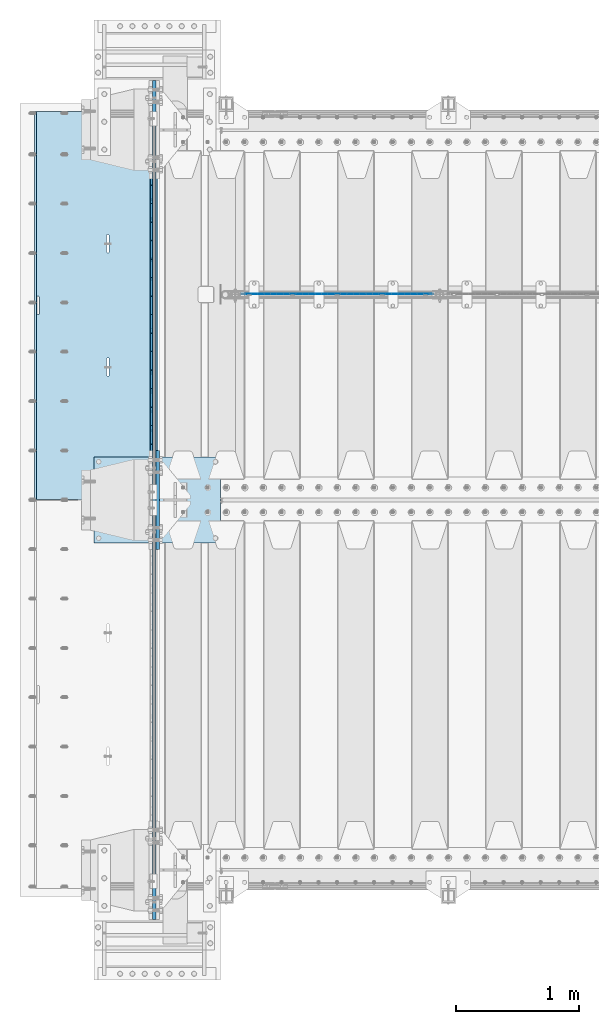
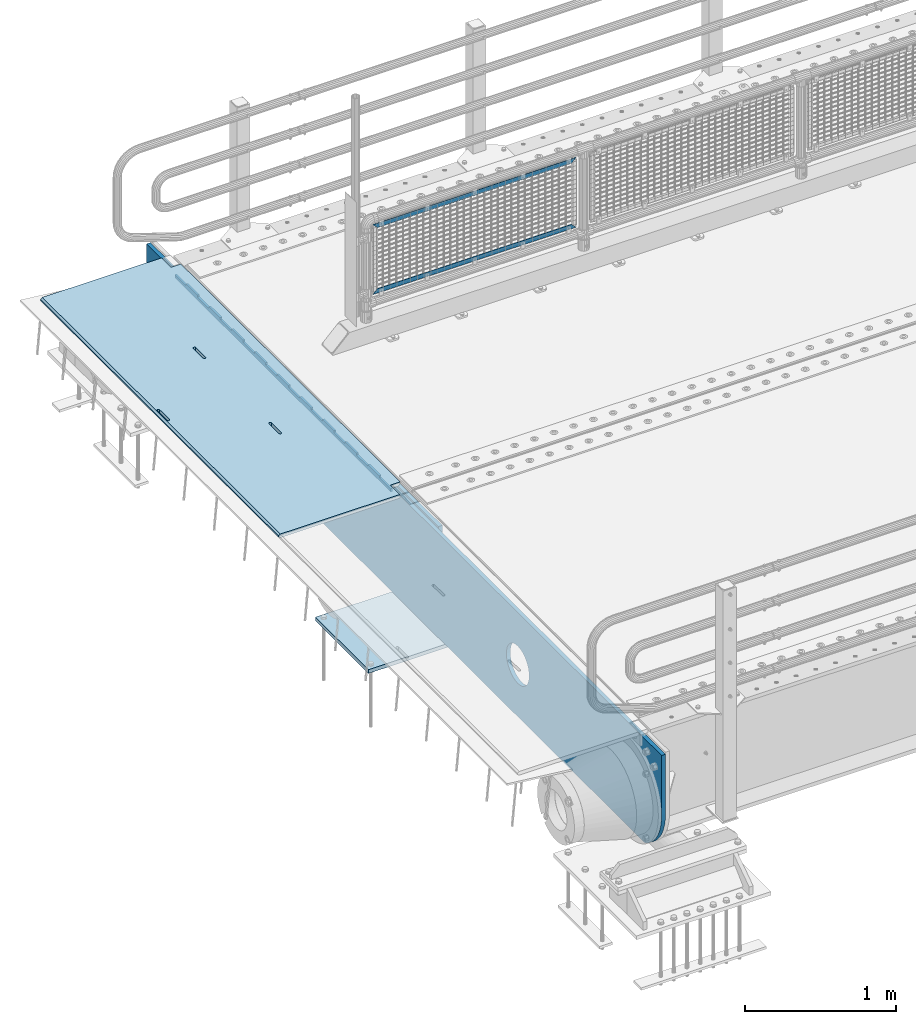
# One storey, part 151 of 193: 7 plates.
"""IFC2X3 building model written with IfcOpenShell, lengths in millimetres."""

from ifc_helpers import new_model, si_unit, frame, origin_with_axes, place, context, subcontext, project, spatial, faceted_brep, material, type_object, element, save


model = new_model("IFC2X3")

# Units and contexts
model_context = context("Model", 3, precision=1e-05, world=origin_with_axes())
body_context = subcontext(model_context, "Body", "Model", "MODEL_VIEW")
ifc_project = project(units=[si_unit("LENGTHUNIT", "METRE", prefix="MILLI"), si_unit("AREAUNIT", "SQUARE_METRE"), si_unit("VOLUMEUNIT", "CUBIC_METRE"), si_unit("MASSUNIT", "GRAM", prefix="KILO"), si_unit("TIMEUNIT", "SECOND"), si_unit("PLANEANGLEUNIT", "RADIAN"), si_unit("SOLIDANGLEUNIT", "STERADIAN"), si_unit("THERMODYNAMICTEMPERATUREUNIT", "DEGREE_CELSIUS"), si_unit("LUMINOUSINTENSITYUNIT", "LUMEN")], contexts=[model_context])

# Site, building, storey
site_placement = place(None, origin_with_axes())
site = spatial("IfcSite", under=ifc_project, at=site_placement, CompositionType="ELEMENT")
building_placement = place(site_placement, origin_with_axes())
building = spatial("IfcBuilding", under=site, at=building_placement, Name="Standard", CompositionType="ELEMENT")
storey_placement = place(building_placement, origin_with_axes())
storey = spatial("IfcBuildingStorey", under=building, at=storey_placement, Name="Undefined", CompositionType="ELEMENT", Elevation=0.0)

# Plates
ifc_material_1 = material(Name="STEEL/S355N")
plate_type_1 = type_object("IfcPlateType", PredefinedType="NOTDEFINED")
plate_1_placement = place(storey_placement, frame((-42455.0037545708, 30149.9999261294, -0.984391683580506), z_axis=(1.0000003385235e-09, -0.999999999987744, -4.95099999993936e-06), x_axis=(-0.999999999879068, -1.00000022173606e-09, -1.55519999981193e-05)))
element("IfcPlate", 1, at=plate_1_placement, inside=storey, type_object=plate_type_1, material=ifc_material_1, context=body_context, shape_type="Brep", body=[
    faceted_brep([(14.9998601691696, 15.0, 125.00002482082), (-0.000294611323624849, -0.000806902962788181, 124.99993624862), (-0.00191941575758392, 0.000806844426834874, 3020.00000492302), (14.9966216875182, 15.0, 3020.0000797665), (999.996459960938, 5.0, 0.0), (984.996459960945, 15.0, 3.63797880709171e-12), (984.996459718794, 15.0, 3145.0), (999.996459718786, 5.0, 3145.0), (984.99645996136, -15.0, 3.63797880709171e-12), (999.996459960938, -4.99999999999848, 0.0), (999.996459718786, -4.99999999999849, 3145.0), (984.996459719208, -15.0, 3145.0), (394.996621833991, -14.9999999992854, 1137.4999999981), (394.996621833998, 15.0, 1137.4999999981), (395.486056670808, 15.0, 1140.59016994185), (395.486056670801, -14.9999999992867, 1140.59016994185), (396.906451889779, 15.0, 1143.37785252103), (396.906451889779, -14.9999999992902, 1143.37785252103), (399.118769310437, 15.0, 1145.59016994185), (399.118769310437, -14.9999999992955, 1145.59016994185), (401.906451889503, 15.0, 1147.01056516106), (401.90645188951, -14.999999999302, 1147.01056516106), (404.996621833212, 15.0, 1147.4999999981), (404.996621833212, -14.9999999993092, 1147.4999999981), (408.086791776994, 15.0, 1147.01056516105), (408.086791776994, -14.9999999993163, 1147.01056516106), (410.874474356286, 15.0, 1145.59016994185), (410.874474356286, -14.9999999993227, 1145.59016994185), (413.086791777278, 15.0, 1143.37785252103), (413.086791777278, -14.9999999993277, 1143.37785252103), (414.5071869967, 15.0, 1140.59016994184), (414.507186996707, -14.9999999993308, 1140.59016994184), (414.996621833976, 15.0, 1137.49999999809), (414.996621833976, -14.9999999993318, 1137.49999999809), (414.996621843893, 15.0, 1007.49999999809), (414.996621843893, -14.9999999993243, 1007.49999999809), (414.507187007082, 15.0, 1004.40983005434), (414.50718700709, -14.999999999323, 1004.40983005435), (413.086791788097, 15.0, 1001.62214747518), (413.086791788097, -14.9999999993196, 1001.62214747518), (410.87447436744, 15.0, 999.409830054352), (410.87447436744, -14.9999999993143, 999.409830054352), (408.086791788373, 15.0, 997.989434835148), (408.086791788373, -14.9999999993078, 997.989434835152), (404.996621844781, 15.0, 997.499999998101), (404.996621844781, -14.9999999993006, 997.499999998101), (401.906451900992, 15.0, 997.989434835152), (401.906451900999, -14.9999999992934, 997.989434835152), (399.1187693217, 15.0, 999.409830054352), (399.118769321707, -14.999999999287, 999.409830054352), (396.906451900715, 15.0, 1001.62214747518), (396.906451900715, -14.999999999282, 1001.62214747518), (395.486056681293, 15.0, 1004.40983005435), (395.486056681293, -14.9999999992789, 1004.40983005435), (394.99662184401, 15.0, 1007.4999999981), (394.99662184401, -14.999999999278, 1007.4999999981), (960.486056642796, -15.0000000006174, 1504.4098300541), (960.486056642796, 15.0, 1504.4098300541), (959.996621805512, 15.0, 1507.49999999785), (959.996621805512, -15.0000000006165, 1507.49999999785), (961.906451862218, -15.0000000006206, 1501.62214747493), (961.906451862218, 15.0, 1501.62214747493), (964.118769283217, -15.0000000006256, 1499.4098300541), (964.11876928321, 15.0, 1499.4098300541), (966.906451862502, -15.0000000006319, 1497.9894348349), (966.906451862495, 15.0, 1497.9894348349), (969.996621806284, -15.0000000006391, 1497.49999999785), (969.996621806284, 15.0, 1497.49999999785), (973.086791749884, -15.0000000006463, 1497.9894348349), (973.086791749884, 15.0, 1497.9894348349), (975.874474328943, -15.0000000006528, 1499.4098300541), (975.874474328943, 15.0, 1499.4098300541), (978.0867917496, -15.0000000006581, 1501.62214747492), (978.0867917496, 15.0, 1501.62214747492), (979.507186968585, -15.0000000006615, 1504.4098300541), (979.507186968578, 15.0, 1504.4098300541), (979.996621805396, -15.0000000006628, 1507.49999999784), (979.996621805396, 15.0, 1507.49999999784), (979.996621795486, -15.0000000006703, 1637.49999999784), (979.996621795486, 15.0, 1637.49999999784), (979.50718695821, -15.0000000006694, 1640.5901699416), (979.507186958203, 15.0, 1640.5901699416), (978.08679173878, -15.0000000006662, 1643.37785252077), (978.08679173878, 15.0, 1643.37785252077), (975.874474317789, -15.0000000006612, 1645.5901699416), (975.874474317789, 15.0, 1645.5901699416), (973.086791738504, -15.0000000006549, 1647.01056516081), (973.086791738504, 15.0, 1647.01056516081), (969.996621794708, -15.0000000006477, 1647.49999999785), (969.996621794715, 15.0, 1647.49999999785), (966.906451851013, -15.0000000006405, 1647.0105651608), (966.906451851006, 15.0, 1647.0105651608), (964.118769271947, -15.000000000634, 1645.5901699416), (964.118769271947, 15.0, 1645.5901699416), (961.906451851282, -15.0000000006287, 1643.37785252078), (961.906451851282, 15.0, 1643.37785252078), (960.486056632304, -15.0000000006253, 1640.5901699416), (960.486056632304, 15.0, 1640.5901699416), (959.996621795493, -15.000000000624, 1637.49999999785), (959.996621795493, 15.0, 1637.49999999785), (-0.000449375176685862, -14.9999999951863, 124.999861417731), (-0.000460362061858177, -15.00000004538, 3019.99993008589), (74.9964039659026, -14.999999998652, 3019.9999301541), (74.9968705259016, 15.0, 3020.0000798241), (74.9962640910162, -15.0, 3145.0), (74.9967306510152, 15.0, 3145.0), (74.9997820616045, -15.0, 3.63797880709171e-12), (75.0002485915975, 15.0, 0.0), (74.9996421867036, -15.0, 124.99993008409), (75.0001087167111, 15.0, 125.000079754089), (395.4860565938, -15.0000000032097, 2140.59016994137), (396.906451812785, -15.0000000031847, 2143.37785252055), (399.118769233435, -15.0000000031445, 2145.59016994137), (401.906451812501, -15.0000000030931, 2147.01056516058), (404.996621756211, -15.0000000030354, 2147.49999999762), (408.086791699992, -15.0000000029771, 2147.01056516058), (410.874474279277, -15.000000002924, 2145.59016994137), (413.086791700283, -15.0000000028812, 2143.37785252055), (414.507186919698, -15.000000002853, 2140.59016994136), (414.996621756974, -15.000000002842, 2137.49999999761), (414.996621766892, -15.0000000027658, 2007.49999999761), (414.507186930088, -15.0000000027732, 2004.40983005387), (413.086791711088, -15.0000000027982, 2001.6221474747), (410.874474290431, -15.0000000028384, 1999.40983005387), (408.086791711372, -15.0000000028898, 1997.98943483467), (404.996621767779, -15.0000000029475, 1997.49999999762), (401.90645182399, -15.0000000030057, 1997.98943483468), (399.118769244706, -15.0000000030589, 1999.40983005387), (396.906451823714, -15.0000000031016, 2001.6221474747), (395.486056604299, -15.0000000031299, 2004.40983005387), (394.996621767008, -15.0000000031409, 2007.49999999762), (394.996621756989, -15.0000000032171, 2137.49999999762), (396.906451823714, 15.0, 2001.6221474747), (395.486056604299, 15.0, 2004.40983005387), (399.118769244698, 15.0, 1999.40983005387), (401.906451823983, 15.0, 1997.98943483467), (404.996621767779, 15.0, 1997.49999999762), (408.086791711372, 15.0, 1997.98943483467), (410.874474290438, 15.0, 1999.40983005387), (413.086791711095, 15.0, 2001.62214747469), (414.507186930081, 15.0, 2004.40983005386), (414.996621766892, 15.0, 2007.49999999761), (414.996621756974, 15.0, 2137.49999999761), (414.507186919691, 15.0, 2140.59016994136), (413.086791700283, 15.0, 2143.37785252055), (410.874474279284, 15.0, 2145.59016994137), (408.086791699992, 15.0, 2147.01056516057), (404.996621756211, 15.0, 2147.49999999762), (401.906451812494, 15.0, 2147.01056516057), (399.118769233435, 15.0, 2145.59016994137), (396.906451812785, 15.0, 2143.37785252055), (395.4860565938, 15.0, 2140.59016994137), (394.996621756989, 15.0, 2137.49999999762), (394.996621767008, 15.0, 2007.49999999762)], [[[0, 1, 2, 3]], [[4, 5, 6, 7]], [[8, 9, 10, 11]], [[12, 13, 14, 15]], [[15, 14, 16, 17]], [[17, 16, 18, 19]], [[19, 18, 20, 21]], [[21, 20, 22, 23]], [[23, 22, 24, 25]], [[25, 24, 26, 27]], [[27, 26, 28, 29]], [[29, 28, 30, 31]], [[31, 30, 32, 33]], [[33, 32, 34, 35]], [[35, 34, 36, 37]], [[37, 36, 38, 39]], [[39, 38, 40, 41]], [[41, 40, 42, 43]], [[43, 42, 44, 45]], [[45, 44, 46, 47]], [[47, 46, 48, 49]], [[49, 48, 50, 51]], [[51, 50, 52, 53]], [[53, 52, 54, 55]], [[55, 54, 13, 12]], [[56, 57, 58, 59]], [[60, 61, 57, 56]], [[62, 63, 61, 60]], [[64, 65, 63, 62]], [[66, 67, 65, 64]], [[68, 69, 67, 66]], [[70, 71, 69, 68]], [[72, 73, 71, 70]], [[74, 75, 73, 72]], [[76, 77, 75, 74]], [[78, 79, 77, 76]], [[80, 81, 79, 78]], [[82, 83, 81, 80]], [[84, 85, 83, 82]], [[86, 87, 85, 84]], [[88, 89, 87, 86]], [[90, 91, 89, 88]], [[92, 93, 91, 90]], [[94, 95, 93, 92]], [[96, 97, 95, 94]], [[98, 99, 97, 96]], [[59, 58, 99, 98]], [[100, 101, 2, 1]], [[101, 102, 103, 3, 2]], [[104, 105, 103, 102]], [[7, 6, 105, 104, 11, 10]], [[4, 7, 10, 9]], [[106, 107, 5, 4, 9, 8]], [[106, 108, 109, 107]], [[109, 108, 100, 1, 0]], [[104, 102, 101, 100, 108, 106, 8, 11], [15, 17, 19, 21, 23, 25, 27, 29, 31, 33, 35, 37, 39, 41, 43, 45, 47, 49, 51, 53, 55, 12], [96, 94, 92, 90, 88, 86, 84, 82, 80, 78, 76, 74, 72, 70, 68, 66, 64, 62, 60, 56, 59, 98], [110, 111, 112, 113, 114, 115, 116, 117, 118, 119, 120, 121, 122, 123, 124, 125, 126, 127, 128, 129, 130, 131]], [[128, 132, 133, 129]], [[127, 134, 132, 128]], [[126, 135, 134, 127]], [[125, 136, 135, 126]], [[124, 137, 136, 125]], [[123, 138, 137, 124]], [[122, 139, 138, 123]], [[121, 140, 139, 122]], [[120, 141, 140, 121]], [[119, 142, 141, 120]], [[118, 143, 142, 119]], [[117, 144, 143, 118]], [[116, 145, 144, 117]], [[115, 146, 145, 116]], [[114, 147, 146, 115]], [[113, 148, 147, 114]], [[112, 149, 148, 113]], [[111, 150, 149, 112]], [[110, 151, 150, 111]], [[131, 152, 151, 110]], [[130, 153, 152, 131]], [[129, 133, 153, 130]], [[107, 109, 0, 3, 103, 105, 6, 5], [50, 48, 46, 44, 42, 40, 38, 36, 34, 32, 30, 28, 26, 24, 22, 20, 18, 16, 14, 13, 54, 52], [132, 134, 135, 136, 137, 138, 139, 140, 141, 142, 143, 144, 145, 146, 147, 148, 149, 150, 151, 152, 153, 133], [61, 63, 65, 67, 69, 71, 73, 75, 77, 79, 81, 83, 85, 87, 89, 91, 93, 95, 97, 99, 58, 57]]]),
])
plate_type_2 = type_object("IfcPlateType", PredefinedType="NOTDEFINED")
plate_2_placement = place(storey_placement, frame((-42507.5, 30002.5000993725, -35.9858217417067), z_axis=(1.0000003385235e-09, -0.999999999987744, -4.95099999993936e-06), x_axis=(0.0, 4.95100000930962e-06, -0.999999999987744)))
element("IfcPlate", 2, at=plate_2_placement, inside=storey, type_object=plate_type_2, material=ifc_material_1, context=body_context, shape_type="Brep", body=[
    faceted_brep([(0.0, -7.5, -3.63797880709171e-12), (8.68993765834603e-12, -7.5, 150.0), (8.68993765834603e-12, 7.5, 150.0), (0.0, 7.5, -3.63797880709171e-12), (-14.9999999999986, -7.5, 149.999999999996), (-14.9999999999986, 7.5, 149.999999999996), (-14.9999999999972, -7.5, 300.0), (-14.9999999999972, 7.5, 300.0), (1.55395696310734e-11, -7.5, 300.0), (1.55395696310734e-11, 7.5, 300.0), (1.87725390787818e-11, -7.5, 449.999999999996), (1.87725390787818e-11, 7.5, 449.999999999996), (-14.9999999999958, -7.5, 449.999999999996), (-14.9999999999958, 7.5, 449.999999999996), (-14.9999999999944, -7.5, 599.999999999996), (-14.9999999999944, 7.5, 599.999999999996), (2.74553713097703e-11, -7.5, 600.0), (2.74553713097703e-11, 7.5, 600.0), (3.24931193063094e-11, -7.5, 750.0), (3.24931193063094e-11, 7.5, 750.0), (-14.999999999993, -7.5, 750.0), (-14.999999999993, 7.5, 750.0), (-14.9999999999916, -7.5, 900.0), (-14.9999999999916, 7.5, 900.0), (4.11830569646554e-11, -7.5, 899.999999999996), (4.11830569646554e-11, 7.5, 899.999999999996), (4.62208049611945e-11, -7.5, 1050.0), (4.62208049611945e-11, 7.5, 1050.0), (-14.9999999999902, -7.5, 1050.0), (-14.9999999999902, 7.5, 1050.0), (-14.9999999999888, -7.5, 1200.0), (-14.9999999999888, 7.5, 1200.0), (5.30917532159947e-11, -7.5, 1200.0), (5.30917532159947e-11, 7.5, 1200.0), (5.99484906160797e-11, -7.5, 1350.0), (5.99484906160797e-11, 7.5, 1350.0), (-14.9999999999873, -7.5, 1350.0), (-14.9999999999873, 7.5, 1350.0), (-14.9999999999859, -7.5, 1500.0), (-14.9999999999859, 7.5, 1500.0), (6.49933440399764e-11, -7.5, 1500.0), (6.49933440399764e-11, 7.5, 1500.0), (7.36761762709648e-11, -7.5, 1650.0), (7.36761762709648e-11, 7.5, 1650.0), (-14.9999999999845, -7.5, 1650.0), (-14.9999999999845, 7.5, 1650.0), (-14.9999999999831, -7.5, 1800.0), (-14.9999999999831, 7.5, 1800.0), (7.6894934863958e-11, -7.5, 1800.0), (7.6894934863958e-11, 7.5, 1800.0), (8.37587776914006e-11, -7.5, 1950.0), (8.37587776914006e-11, 7.5, 1950.0), (-14.9999999999817, -7.5, 1950.0), (-14.9999999999817, 7.5, 1950.0), (-14.9999999999803, -7.5, 2100.0), (-14.9999999999803, 7.5, 2100.0), (9.06297259462008e-11, -7.5, 2100.0), (9.06297259462008e-11, 7.5, 2100.0), (9.56674739427399e-11, -7.5, 2250.0), (9.56674739427399e-11, 7.5, 2250.0), (-14.9999999999789, -7.5, 2250.0), (-14.9999999999789, 7.5, 2250.0), (-14.9999999999775, -7.5, 2400.0), (-14.9999999999775, 7.5, 2400.0), (1.04350306173728e-10, -7.5, 2400.0), (1.04350306173728e-10, 7.5, 2400.0), (1.09388054170267e-10, -7.5, 2550.0), (1.09388054170267e-10, 7.5, 2550.0), (-14.9999999999761, -7.5, 2550.0), (-14.9999999999761, 7.5, 2550.0), (-14.9999999999747, -7.5, 2700.0), (-14.9999999999747, 7.5, 2700.0), (1.14440013021522e-10, -7.5, 2700.0), (1.14440013021522e-10, 7.5, 2700.0), (1.23115739825153e-10, -7.5, 2850.0), (1.23115739825153e-10, 7.5, 2850.0), (25.0000000000267, -7.5, 2850.0), (25.0000000000267, 7.5, 2850.0), (25.0, -7.5, -3.63797880709171e-12), (25.0, 7.5, -3.63797880709171e-12)], [[[0, 1, 2, 3]], [[1, 4, 5, 2]], [[4, 6, 7, 5]], [[6, 8, 9, 7]], [[8, 10, 11, 9]], [[10, 12, 13, 11]], [[12, 14, 15, 13]], [[14, 16, 17, 15]], [[16, 18, 19, 17]], [[18, 20, 21, 19]], [[20, 22, 23, 21]], [[22, 24, 25, 23]], [[24, 26, 27, 25]], [[26, 28, 29, 27]], [[28, 30, 31, 29]], [[30, 32, 33, 31]], [[32, 34, 35, 33]], [[34, 36, 37, 35]], [[36, 38, 39, 37]], [[38, 40, 41, 39]], [[40, 42, 43, 41]], [[42, 44, 45, 43]], [[44, 46, 47, 45]], [[46, 48, 49, 47]], [[48, 50, 51, 49]], [[50, 52, 53, 51]], [[52, 54, 55, 53]], [[54, 56, 57, 55]], [[56, 58, 59, 57]], [[58, 60, 61, 59]], [[60, 62, 63, 61]], [[62, 64, 65, 63]], [[64, 66, 67, 65]], [[66, 68, 69, 67]], [[68, 70, 71, 69]], [[70, 72, 73, 71]], [[72, 74, 75, 73]], [[74, 76, 77, 75]], [[76, 78, 79, 77]], [[78, 0, 3, 79]], [[5, 7, 9, 11, 13, 15, 17, 19, 21, 23, 25, 27, 29, 31, 33, 35, 37, 39, 41, 43, 45, 47, 49, 51, 53, 55, 57, 59, 61, 63, 65, 67, 69, 71, 73, 75, 77, 79, 3, 2]], [[78, 76, 74, 72, 70, 68, 66, 64, 62, 60, 58, 56, 54, 52, 50, 48, 46, 44, 42, 40, 38, 36, 34, 32, 30, 28, 26, 24, 22, 20, 18, 16, 14, 12, 10, 8, 6, 4, 1, 0]]]),
])
ifc_material_2 = material(Name="Misc_Undefined")
plate_type_3 = type_object("IfcPlateType", PredefinedType="NOTDEFINED")
plate_3_placement = place(storey_placement, frame((-41775.4949882696, 28670.5, 351.520303374641), z_axis=(0.0, 0.0, 1.0), x_axis=(1.0, 0.0, 0.0)))
element("IfcPlate", 3, at=plate_3_placement, inside=storey, type_object=plate_type_3, material=ifc_material_2, context=body_context, shape_type="Brep", body=[
    faceted_brep([(0.0, -1.49999999999636, 3.63797880709171e-12), (35.0002975463831, -1.5, 34.9996948242187), (35.0002975463831, 1.5, 34.9996948242187), (0.0, 1.50000000000364, 7.27595761418343e-12), (1515.99035644531, -1.5, 34.9999923706054), (1515.99035644531, 1.5, 34.9999923706054), (1550.98999023437, -1.5, 4.43037606601138e-09), (1550.98999023437, 1.5, 4.43037606601138e-09)], [[[0, 1, 2, 3]], [[1, 4, 5, 2]], [[4, 6, 7, 5]], [[6, 0, 3, 7]], [[5, 7, 3, 2]], [[6, 4, 1, 0]]]),
])
plate_4_placement = place(storey_placement, frame((-40224.4999998124, 28670.5, 914.520000175701), z_axis=(-0.707103624179499, 0.0, 0.707109938179501), x_axis=(-0.707109938179501, 0.0, -0.707103624179499)))
element("IfcPlate", 4, at=plate_4_placement, inside=storey, type_object=plate_type_3, material=ifc_material_2, context=body_context, shape_type="Brep", body=[
    faceted_brep([(0.0, -1.49999999999636, 3.63797880709171e-12), (1096.7275390625, -1.5, 1096.7177734375), (1096.7275390625, 1.5, 1096.7177734375), (0.0, 1.50000000000364, 7.27595761418343e-12), (1096.72045898438, -1.5, 1047.21337890625), (1096.72045898438, 1.5, 1047.21337890625), (49.4976959228552, -1.5, -1.01863406598568e-10), (49.4976959228552, 1.5, -1.01863406598568e-10)], [[[0, 1, 2, 3]], [[1, 4, 5, 2]], [[4, 6, 7, 5]], [[6, 0, 3, 7]], [[5, 7, 3, 2]], [[6, 4, 1, 0]]]),
])
plate_type_4 = type_object("IfcPlateType", PredefinedType="NOTDEFINED")
plate_5_placement = place(storey_placement, frame((-42974.0, 27350.0, -1043.0), z_axis=(1.0, 0.0, 0.0), x_axis=(0.0, -1.0, 0.0)))
element("IfcPlate", 5, at=plate_5_placement, inside=storey, type_object=plate_type_4, material=ifc_material_1, context=body_context, shape_type="Brep", body=[
    faceted_brep([(0.0, -15.0, 0.0), (2.93249104288407e-06, -15.0, 1025.0), (2.93249104288407e-06, 15.0, 1025.0), (0.0, 15.0, 0.0), (700.0, -15.0, 1025.0), (700.0, 15.0, 1025.0), (700.0, -15.0, -7.27595761418343e-12), (700.0, 15.0, -7.27595761418343e-12)], [[[0, 1, 2, 3]], [[1, 4, 5, 2]], [[4, 6, 7, 5]], [[6, 0, 3, 7]], [[5, 7, 3, 2]], [[6, 4, 1, 0]]]),
])
plate_type_5 = type_object("IfcPlateType", PredefinedType="NOTDEFINED")
plate_6_placement = place(storey_placement, frame((-42455.0, 26600.0, -20.0), z_axis=(0.0, 1.0, 0.0), x_axis=(0.0, 0.0, -1.0)))
element("IfcPlate", 6, at=plate_6_placement, inside=storey, type_object=plate_type_5, material=ifc_material_1, context=body_context, shape_type="Brep", body=[
    faceted_brep([(855.0, -15.0, 572.963114671471), (855.0, 15.0, 572.963114671471), (849.182410261268, 15.0, 585.889268817518), (849.182410261268, -15.0, 585.889268817518), (824.19354635745, 15.0, 627.225898692468), (824.19354635745, -15.0, 627.225898692468), (794.404299268433, 15.0, 665.249063296324), (794.404299268433, -15.0, 665.249063296324), (760.249063296315, 15.0, 699.404299268441), (760.249063296315, -15.0, 699.404299268441), (722.225898692465, 15.0, 729.193546357463), (722.225898692465, -15.0, 729.193546357463), (680.889268817516, 15.0, 754.182410261281), (680.889268817516, -15.0, 754.182410261281), (636.841954817028, 15.0, 774.006497074162), (636.841954817028, -15.0, 774.006497074162), (590.726265715042, 15.0, 788.376726970419), (590.726265715042, -15.0, 788.376726970419), (543.214672102154, 15.0, 797.083549639221), (543.214672102154, -15.0, 797.083549639221), (495.0, -15.0, 800.000000000029), (495.0, 15.0, 800.0), (494.999999999412, -15.0, 0.0), (494.999999999412, 15.0, 0.0), (543.214672102129, 15.0, 2.91645036080809), (543.214672102129, -15.0, 2.91645036080809), (590.726265715023, 15.0, 11.6232730296069), (590.726265715023, -15.0, 11.6232730296069), (636.841954817014, 15.0, 25.9935029258631), (636.841954817014, -15.0, 25.9935029258631), (680.889268817507, 15.0, 45.8175897387446), (680.889268817507, -15.0, 45.8175897387446), (722.225898692462, 15.0, 70.8064536425663), (722.225898692462, -15.0, 70.8064536425663), (760.249063296318, 15.0, 100.595700731588), (760.249063296318, -15.0, 100.595700731588), (794.404299268441, 15.0, 134.750936703713), (794.404299268441, -15.0, 134.750936703713), (824.193546357463, 15.0, 172.774101307568), (824.193546357463, -15.0, 172.774101307568), (849.182410261284, 15.0, 214.110731182522), (849.182410261284, -15.0, 214.110731182522), (855.0, -15.0, 227.036885328536), (855.0, 15.0, 227.036885328536), (0.0, -15.0, 0.0), (0.0, 15.0, 0.0), (0.0, 15.0, 800.0), (0.0, -15.0, 800.0)], [[[0, 1, 2, 3]], [[3, 2, 4, 5]], [[5, 4, 6, 7]], [[7, 6, 8, 9]], [[9, 8, 10, 11]], [[11, 10, 12, 13]], [[13, 12, 14, 15]], [[15, 14, 16, 17]], [[17, 16, 18, 19]], [[20, 19, 18, 21]], [[22, 23, 24, 25]], [[25, 24, 26, 27]], [[27, 26, 28, 29]], [[29, 28, 30, 31]], [[31, 30, 32, 33]], [[33, 32, 34, 35]], [[35, 34, 36, 37]], [[37, 36, 38, 39]], [[39, 38, 40, 41]], [[42, 41, 40, 43]], [[42, 43, 1, 0]], [[44, 45, 23, 22]], [[16, 14, 12, 10, 8, 6, 4, 2, 1, 43, 40, 38, 36, 34, 32, 30, 28, 26, 24, 23, 45, 46, 21, 18]], [[44, 47, 46, 45]], [[46, 47, 20, 21]], [[47, 44, 22, 25, 27, 29, 31, 33, 35, 37, 39, 41, 42, 0, 3, 5, 7, 9, 11, 13, 15, 17, 19, 20]]]),
])
plate_type_6 = type_object("IfcPlateType", PredefinedType="NOTDEFINED")
plate_7_placement = place(storey_placement, frame((-42485.0, 23600.0, -35.9999830912049), z_axis=(0.0, 1.0, 0.0), x_axis=(0.0, 0.0, -1.0)))
element("IfcPlate", 7, at=plate_7_placement, inside=storey, type_object=plate_type_6, material=ifc_material_1, context=body_context, shape_type="Brep", body=[
    faceted_brep([(449.263580031862, -15.0, 2047.11778936592), (449.263580031862, 15.0, 2047.11778936592), (477.402546532991, 15.0, 2038.58192701329), (477.402546532991, -15.0, 2038.58192701329), (503.335566547999, 15.0, 2024.72043882638), (503.335566547999, -15.0, 2024.72043882638), (526.066048661114, 15.0, 2006.0660140226), (526.066048661114, -15.0, 2006.0660140226), (544.720473192131, 15.0, 1983.33553168563), (544.720473192131, -15.0, 1983.33553168563), (558.581961067844, 15.0, 1957.40251150429), (558.581961067844, -15.0, 1957.40251150429), (567.117823082802, 15.0, 1929.26354490073), (567.117823082802, -15.0, 1929.26354490073), (570.000030846736, 15.0, 1899.99999658101), (570.000030846736, -15.0, 1899.99999658101), (567.117822731639, 15.0, 1870.73644829589), (567.117822731639, -15.0, 1870.73644829589), (558.581960379014, 15.0, 1842.59748179476), (558.581960379014, -15.0, 1842.59748179476), (544.720472192104, 15.0, 1816.66446177975), (544.720472192104, -15.0, 1816.66446177975), (526.066047388322, 15.0, 1793.93397966664), (526.066047388322, -15.0, 1793.93397966664), (503.335565051353, 15.0, 1775.27955513562), (503.335565051353, -15.0, 1775.27955513562), (477.402544870008, 15.0, 1761.4180672599), (477.402544870008, -15.0, 1761.4180672599), (449.263578266448, 15.0, 1752.88220524495), (449.263578266448, -15.0, 1752.88220524495), (420.000029946736, 15.0, 1749.99999748101), (420.000029946736, -15.0, 1749.99999748101), (390.73648166161, 15.0, 1752.88220559611), (390.73648166161, -15.0, 1752.88220559611), (362.597515160481, 15.0, 1761.41806794873), (362.597515160481, -15.0, 1761.41806794873), (336.664495145473, 15.0, 1775.27955613565), (336.664495145473, -15.0, 1775.27955613565), (313.934013032358, 15.0, 1793.93398093943), (313.934013032358, -15.0, 1793.93398093943), (295.279588501341, 15.0, 1816.6644632764), (295.279588501341, -15.0, 1816.6644632764), (281.418100625628, 15.0, 1842.59748345774), (281.418100625628, -15.0, 1842.59748345774), (272.88223861067, 15.0, 1870.7364500613), (272.88223861067, -15.0, 1870.7364500613), (270.000030846736, 15.0, 1899.99999838101), (270.000030846736, -15.0, 1899.99999838101), (272.882238961832, 15.0, 1929.26354666614), (272.882238961832, -15.0, 1929.26354666614), (281.418101314458, 15.0, 1957.40251316727), (281.418101314458, -15.0, 1957.40251316727), (295.279589501367, 15.0, 1983.33553318228), (295.279589501367, -15.0, 1983.33553318228), (313.93401430515, 15.0, 2006.06601529539), (313.93401430515, -15.0, 2006.06601529539), (336.664496642118, 15.0, 2024.72043982641), (336.664496642118, -15.0, 2024.72043982641), (362.597516823464, 15.0, 2038.58192770212), (362.597516823464, -15.0, 2038.58192770212), (390.736483427023, 15.0, 2047.11778971708), (390.736483427023, -15.0, 2047.11778971708), (420.000031746736, 15.0, 2049.99999748101), (420.000031746736, -15.0, 2049.99999748101), (-9.46770349230519e-07, 15.0, 6800.0), (-9.46770349230519e-07, -15.0, 6800.0), (479.000057698847, -15.0, 6799.9999971271), (479.000057668836, 15.0, 6800.0), (0.0, -15.0, 0.0), (0.0, 15.0, 0.0), (479.000000000116, 15.0, 3.63797880709171e-12), (479.000000000116, -15.0, 3.63797880709171e-12), (527.214672103482, 15.0, 2.91645035950569), (527.214672103482, -14.9999999999927, 2.91645035950569), (574.726265716376, 15.0, 11.6232730283009), (574.726265716376, -14.9999999999927, 11.6232730283009), (620.841954818367, 15.0, 25.9935029245571), (620.841954818367, -14.9999999999927, 25.9935029245571), (664.88926881886, 15.0, 45.8175897374385), (664.88926881886, -14.9999999999927, 45.8175897374385), (706.225898693815, 15.0, 70.8064536412603), (706.225898693815, -14.9999999999927, 70.8064536412603), (744.249063297671, 15.0, 100.595700730286), (744.249063297671, -14.9999999999927, 100.595700730286), (778.404299269793, 15.0, 134.75093670241), (778.404299269793, -14.9999999999927, 134.75093670241), (808.193546358815, 15.0, 172.774101306262), (808.193546358815, -14.9999999999927, 172.774101306262), (833.182410262637, 15.0, 214.110731181219), (833.182410262637, -14.9999999999927, 214.110731181219), (838.999997962172, -15.0, 227.03688079636), (838.999997962172, 15.0, 227.03688079636), (838.999941002682, 15.0, 6572.96326471358), (838.999941002682, -15.0, 6572.96326478024), (833.182425778062, 15.0000000000073, 6585.88925446606), (833.182425808062, -15.0, 6585.88925446606), (808.193562547075, 15.0000000000073, 6627.22588611692), (808.193562577075, -15.0, 6627.22588611692), (778.404315800335, 15.0000000000073, 6665.24905247741), (778.404315830335, -15.0, 6665.24905247741), (744.249079856027, 15.0000000000073, 6699.40429013439), (744.249079886026, -15.0, 6699.40429013439), (706.225914989274, 15.0000000000073, 6729.19353878775), (706.225915019274, -15.0, 6729.19353878775), (664.889284591445, 15.0000000000073, 6754.1824040915), (664.889284621445, -15.0, 6754.1824040915), (620.84196984497, 15.0000000000073, 6774.00649210182), (620.84196987497, -15.0, 6774.00649210182), (574.726279815929, 15.0000000000073, 6788.37672296153), (574.726279845929, -15.0, 6788.37672296153), (527.214685141059, 15.0000000000073, 6797.08354633559), (527.214685171059, -15.0, 6797.08354633559), (477.402561983564, -15.0, 5038.58192701329), (503.335581998572, -15.0, 5024.72043882638), (526.066064111687, -15.0, 5006.0660140226), (544.720488642704, -15.0, 4983.33553168563), (558.581976518417, -15.0, 4957.40251150429), (567.117838533375, -15.0, 4929.26354490073), (570.000046297309, -15.0, 4899.99999658101), (567.117838182212, -15.0, 4870.73644829589), (558.581975829587, -15.0, 4842.59748179476), (544.720487642677, -15.0, 4816.66446177975), (526.066062838895, -15.0, 4793.93397966664), (503.335580501926, -15.0, 4775.27955513562), (477.402560320581, -15.0, 4761.4180672599), (449.263593717021, -15.0, 4752.88220524495), (420.000045397309, -15.0, 4749.99999748101), (390.736497112183, -15.0, 4752.88220559611), (362.597530611054, -15.0, 4761.41806794873), (336.664510596046, -15.0, 4775.27955613565), (313.93402848293, -15.0, 4793.93398093943), (295.279603951914, -15.0, 4816.6644632764), (281.418116076201, -15.0, 4842.59748345774), (272.882254061243, -15.0, 4870.7364500613), (270.000046297309, -15.0, 4899.99999838101), (272.882254412405, -15.0, 4929.26354666614), (281.418116765031, -15.0, 4957.40251316727), (295.27960495194, -15.0, 4983.33553318228), (313.934029755723, -15.0, 5006.06601529539), (336.664512092691, -15.0, 5024.72043982641), (362.597532274037, -15.0, 5038.58192770212), (390.736498877596, -15.0, 5047.11778971708), (420.000047197309, -15.0, 5049.99999748101), (449.263595482435, -15.0, 5047.11778936592), (362.597532274037, 15.0, 5038.58192770212), (390.736498877596, 15.0, 5047.11778971708), (336.664512092691, 15.0, 5024.72043982641), (313.934029755723, 15.0, 5006.06601529539), (295.27960495194, 15.0, 4983.33553318228), (281.418116765031, 15.0, 4957.40251316727), (272.882254412405, 15.0, 4929.26354666614), (270.000046297309, 15.0, 4899.99999838101), (272.882254061243, 15.0, 4870.7364500613), (281.418116076201, 15.0, 4842.59748345774), (295.279603951914, 15.0, 4816.6644632764), (313.93402848293, 15.0, 4793.93398093943), (336.664510596046, 15.0, 4775.27955613565), (362.597530611054, 15.0, 4761.41806794873), (390.736497112183, 15.0, 4752.88220559611), (420.000045397309, 15.0, 4749.99999748101), (449.263593717021, 15.0, 4752.88220524495), (477.402560320581, 15.0, 4761.4180672599), (503.335580501926, 15.0, 4775.27955513562), (526.066062838895, 15.0, 4793.93397966664), (544.720487642677, 15.0, 4816.66446177975), (558.581975829587, 15.0, 4842.59748179476), (567.117838182212, 15.0, 4870.73644829589), (570.000046297309, 15.0, 4899.99999658101), (567.117838533375, 15.0, 4929.26354490073), (558.581976518417, 15.0, 4957.40251150429), (544.720488642704, 15.0, 4983.33553168563), (526.066064111687, 15.0, 5006.0660140226), (503.335581998572, 15.0, 5024.72043882638), (477.402561983564, 15.0, 5038.58192701329), (449.263595482435, 15.0, 5047.11778936592), (420.000047197309, 15.0, 5049.99999748101)], [[[0, 1, 2, 3]], [[3, 2, 4, 5]], [[5, 4, 6, 7]], [[7, 6, 8, 9]], [[9, 8, 10, 11]], [[11, 10, 12, 13]], [[13, 12, 14, 15]], [[15, 14, 16, 17]], [[17, 16, 18, 19]], [[19, 18, 20, 21]], [[21, 20, 22, 23]], [[23, 22, 24, 25]], [[25, 24, 26, 27]], [[27, 26, 28, 29]], [[29, 28, 30, 31]], [[31, 30, 32, 33]], [[33, 32, 34, 35]], [[35, 34, 36, 37]], [[37, 36, 38, 39]], [[39, 38, 40, 41]], [[41, 40, 42, 43]], [[43, 42, 44, 45]], [[45, 44, 46, 47]], [[47, 46, 48, 49]], [[49, 48, 50, 51]], [[51, 50, 52, 53]], [[53, 52, 54, 55]], [[55, 54, 56, 57]], [[57, 56, 58, 59]], [[59, 58, 60, 61]], [[61, 60, 62, 63]], [[63, 62, 1, 0]], [[64, 65, 66, 67]], [[68, 65, 64, 69]], [[68, 69, 70, 71]], [[71, 70, 72, 73]], [[73, 72, 74, 75]], [[75, 74, 76, 77]], [[77, 76, 78, 79]], [[79, 78, 80, 81]], [[81, 80, 82, 83]], [[83, 82, 84, 85]], [[85, 84, 86, 87]], [[87, 86, 88, 89]], [[90, 89, 88, 91]], [[90, 91, 92, 93]], [[93, 92, 94, 95]], [[95, 94, 96, 97]], [[97, 96, 98, 99]], [[99, 98, 100, 101]], [[101, 100, 102, 103]], [[103, 102, 104, 105]], [[105, 104, 106, 107]], [[107, 106, 108, 109]], [[109, 108, 110, 111]], [[66, 111, 110, 67]], [[65, 68, 71, 73, 75, 77, 79, 81, 83, 85, 87, 89, 90, 93, 95, 97, 99, 101, 103, 105, 107, 109, 111, 66], [3, 5, 7, 9, 11, 13, 15, 17, 19, 21, 23, 25, 27, 29, 31, 33, 35, 37, 39, 41, 43, 45, 47, 49, 51, 53, 55, 57, 59, 61, 63, 0], [112, 113, 114, 115, 116, 117, 118, 119, 120, 121, 122, 123, 124, 125, 126, 127, 128, 129, 130, 131, 132, 133, 134, 135, 136, 137, 138, 139, 140, 141, 142, 143]], [[140, 144, 145, 141]], [[139, 146, 144, 140]], [[138, 147, 146, 139]], [[137, 148, 147, 138]], [[136, 149, 148, 137]], [[135, 150, 149, 136]], [[134, 151, 150, 135]], [[133, 152, 151, 134]], [[132, 153, 152, 133]], [[131, 154, 153, 132]], [[130, 155, 154, 131]], [[129, 156, 155, 130]], [[128, 157, 156, 129]], [[127, 158, 157, 128]], [[126, 159, 158, 127]], [[125, 160, 159, 126]], [[124, 161, 160, 125]], [[123, 162, 161, 124]], [[122, 163, 162, 123]], [[121, 164, 163, 122]], [[120, 165, 164, 121]], [[119, 166, 165, 120]], [[118, 167, 166, 119]], [[117, 168, 167, 118]], [[116, 169, 168, 117]], [[115, 170, 169, 116]], [[114, 171, 170, 115]], [[113, 172, 171, 114]], [[112, 173, 172, 113]], [[143, 174, 173, 112]], [[142, 175, 174, 143]], [[141, 145, 175, 142]], [[108, 106, 104, 102, 100, 98, 96, 94, 92, 91, 88, 86, 84, 82, 80, 78, 76, 74, 72, 70, 69, 64, 67, 110], [58, 56, 54, 52, 50, 48, 46, 44, 42, 40, 38, 36, 34, 32, 30, 28, 26, 24, 22, 20, 18, 16, 14, 12, 10, 8, 6, 4, 2, 1, 62, 60], [144, 146, 147, 148, 149, 150, 151, 152, 153, 154, 155, 156, 157, 158, 159, 160, 161, 162, 163, 164, 165, 166, 167, 168, 169, 170, 171, 172, 173, 174, 175, 145]]]),
])

save(model, "model.ifc")
